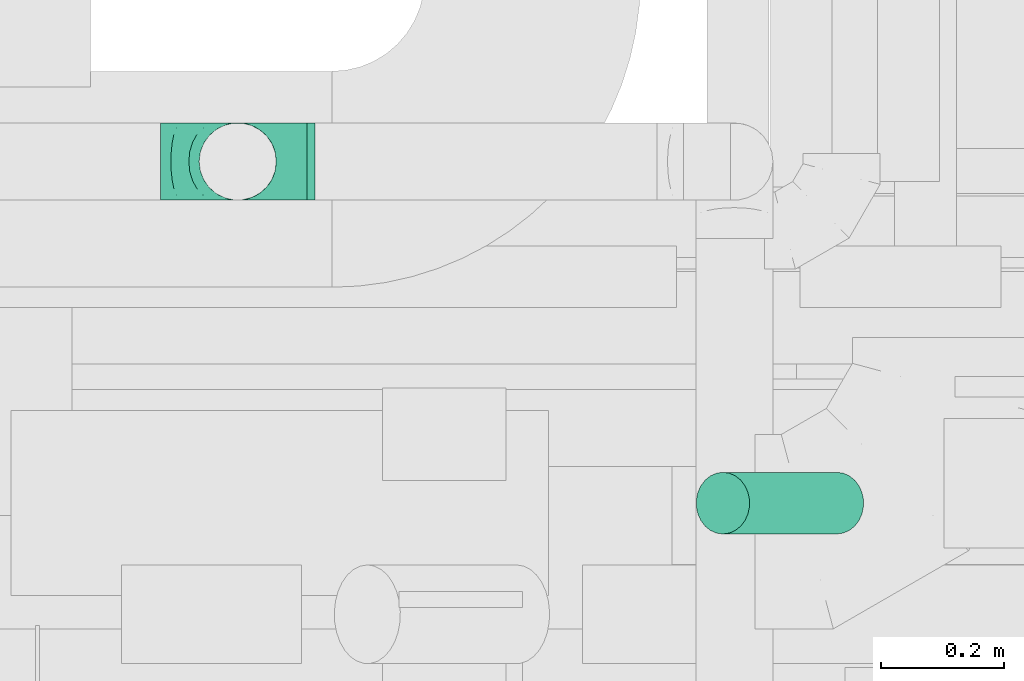
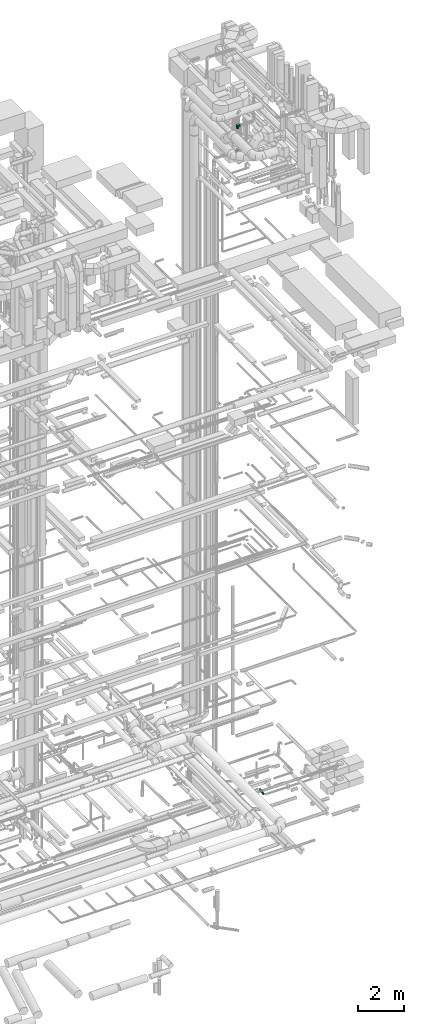
# One storey, part 262 of 337: 3 flow fittings, 1 flow segment.
"""IFC2X3 building model written with IfcOpenShell, lengths in millimetres."""

import ifcopenshell
import ifcopenshell.guid

model = None  # the IFC model being written
_history = None  # IfcOwnerHistory: only IFC2X3 demands one
_inside = {}  # id of a spatial element -> (the spatial element, [elements in it])
_under = {}  # id of a project, library or spatial element -> (it, [spatial elements below it])
_declared = {}  # id of a project -> (the project, [libraries it declares])
_typed = {}  # id of a type object -> (the type object, [elements of that type])
_made_of = {}  # id of a material, layer set ... -> (it, [elements and type objects made of it])


def new_model(schema):
    """Start an empty IFC model of exactly this schema.

    Asked for "IFC4X3", IfcOpenShell would pick the latest addendum, in which some entities
    have other attributes; the version numbers below select the first issue.
    IFC2X3 requires an IfcOwnerHistory on every rooted entity: one is made here for all.
    """
    global model, _history
    if schema == "IFC4X3":
        model = ifcopenshell.file(schema_version=(4, 3, 0, 0))
    else:
        model = ifcopenshell.file(schema=schema)
    _inside.clear()
    _under.clear()
    _declared.clear()
    _typed.clear()
    _made_of.clear()
    _history = None
    if model.schema == "IFC2X3":
        org = make("IfcOrganization", Name="unknown")
        user = make(
            "IfcPersonAndOrganization",
            ThePerson=make("IfcPerson", FamilyName="unknown"),
            TheOrganization=org,
        )
        app = make(
            "IfcApplication",
            ApplicationDeveloper=org,
            Version="unknown",
            ApplicationFullName="unknown",
            ApplicationIdentifier="unknown",
        )
        _history = make(
            "IfcOwnerHistory",
            OwningUser=user,
            OwningApplication=app,
            ChangeAction="ADDED",
            CreationDate=0,
        )
    return model


def make(cls, **values):
    """One entity of the class cls with the attributes given. An attribute that is None is left unset."""
    return model.create_entity(
        cls, **{name: value for name, value in values.items() if value is not None}
    )


def entity(cls, *values):
    """Any entity or typed value of the class cls, its attributes in the order of the schema. None: left unset."""
    e = model.create_entity(cls)
    for i, value in enumerate(values):
        if value is not None:
            e[i] = value
    return e


def rooted(cls, **values):
    """An entity with a GlobalId (a new one), such as an element, a storey or a relation."""
    return make(cls, GlobalId=ifcopenshell.guid.new(), OwnerHistory=_history, **values)


def si_unit(unit_type, name, prefix=None):
    """IfcSIUnit, for example si_unit("LENGTHUNIT", "METRE", prefix="MILLI")."""
    return make("IfcSIUnit", UnitType=unit_type, Prefix=prefix, Name=name)


def converted_unit(unit_type, name, factor, base, dimensions=None, offset=None):
    """IfcConversionBasedUnit, such as the inch: factor (a typed value) times the base unit."""
    return make(
        "IfcConversionBasedUnit"
        if offset is None
        else "IfcConversionBasedUnitWithOffset",
        ConversionOffset=offset,
        Dimensions=None
        if dimensions is None
        else entity("IfcDimensionalExponents", *dimensions),
        UnitType=unit_type,
        Name=name,
        ConversionFactor=make(
            "IfcMeasureWithUnit", ValueComponent=factor, UnitComponent=base
        ),
    )


def derived_unit(unit_type, elements):
    """IfcDerivedUnit: a product of units, each with its exponent."""
    return make(
        "IfcDerivedUnit",
        Elements=[
            make("IfcDerivedUnitElement", Unit=unit, Exponent=power)
            for unit, power in elements
        ],
        UnitType=unit_type,
    )


def assignment(units):
    """IfcUnitAssignment: the units of a project."""
    return None if units is None else make("IfcUnitAssignment", Units=units)


def point(xyz):
    """IfcCartesianPoint."""
    return None if xyz is None else make("IfcCartesianPoint", Coordinates=xyz)


def direction(xyz):
    """IfcDirection."""
    return None if xyz is None else make("IfcDirection", DirectionRatios=xyz)


def frame(location, z_axis=None, x_axis=None):
    """IfcAxis2Placement3D, a coordinate frame: its origin and axes. An axis left out is left unset."""
    return make(
        "IfcAxis2Placement3D",
        Location=point(location),
        Axis=direction(z_axis),
        RefDirection=direction(x_axis),
    )


def frame_2d(location, x_axis=None):
    """IfcAxis2Placement2D, a coordinate frame in the plane: its origin and x axis."""
    return make(
        "IfcAxis2Placement2D", Location=point(location), RefDirection=direction(x_axis)
    )


def origin():
    """The frame at (0, 0, 0) with its axes left unset."""
    return frame((0.0, 0.0, 0.0))


def origin_2d_with_axis():
    """The frame at (0, 0) in the plane with the x axis (1, 0) written out."""
    return frame_2d((0.0, 0.0), x_axis=(1.0, 0.0))


def place(relative_to, where):
    """IfcLocalPlacement: puts the frame where relative to a parent placement (None: the world)."""
    return make(
        "IfcLocalPlacement", PlacementRelTo=relative_to, RelativePlacement=where
    )


def context(
    kind, dimensions, precision=None, world=None, true_north=None, identifier=None
):
    """IfcGeometricRepresentationContext, for example the 3D "Model" context."""
    return make(
        "IfcGeometricRepresentationContext",
        ContextIdentifier=identifier,
        ContextType=kind,
        CoordinateSpaceDimension=dimensions,
        Precision=precision,
        WorldCoordinateSystem=world,
        TrueNorth=true_north,
    )


def subcontext(parent, identifier, kind, view, scale=None):
    """IfcGeometricRepresentationSubContext, for example "Body" below "Model"."""
    return make(
        "IfcGeometricRepresentationSubContext",
        ContextIdentifier=identifier,
        ContextType=kind,
        ParentContext=parent,
        TargetScale=scale,
        TargetView=view,
    )


def project(units=None, contexts=None):
    """IfcProject with its units and contexts."""
    return rooted(
        "IfcProject",
        Name="project",
        RepresentationContexts=contexts,
        UnitsInContext=assignment(units),
    )


def spatial(cls, under=None, at=None, **own):
    """A site, building, storey or space (cls), placed at a placement, below another one or the project."""
    s = rooted(cls, ObjectPlacement=at, **own)
    if under is not None:
        _under.setdefault(under.id(), (under, []))[1].append(s)
    return s


def profile(cls, at=None, kind="AREA", **sizes):
    """A parametric profile (cls). Its sizes go by their IFC names, for example OverallWidth=200.0."""
    return make(cls, ProfileType=kind, Position=at, **sizes)


def circle(**sizes):
    """IfcCircleProfileDef."""
    return profile("IfcCircleProfileDef", **sizes)


def extrude(swept, where, along, depth):
    """IfcExtrudedAreaSolid: the profile swept, set in the frame where, extruded along a direction by depth."""
    return make(
        "IfcExtrudedAreaSolid",
        SweptArea=swept,
        Position=where,
        ExtrudedDirection=direction(along),
        Depth=depth,
    )


def faces_of(points, faces, orient=None, outer=None):
    """IfcFace entities. A face is a list of loops; a loop is a list of indices into points, from 0.

    orient and outer hold one flag for each loop. By default every Orientation is true, the
    first loop of a face is its IfcFaceOuterBound and the others are IfcFaceBound.
    """
    made = []
    for i, loops in enumerate(faces):
        bounds = []
        for j, loop in enumerate(loops):
            is_outer = j == 0 if outer is None else outer[i][j]
            bounds.append(
                make(
                    "IfcFaceOuterBound" if is_outer else "IfcFaceBound",
                    Bound=make("IfcPolyLoop", Polygon=[points[k] for k in loop]),
                    Orientation=True if orient is None else orient[i][j],
                )
            )
        made.append(make("IfcFace", Bounds=bounds))
    return made


def faceted_brep(points, faces, orient=None, outer=None, voids=None):
    """IfcFacetedBrep: a solid bounded by flat faces; with voids (closed shells), ...WithVoids."""
    shared = [point(p) for p in points]
    hull = make("IfcClosedShell", CfsFaces=faces_of(shared, faces, orient, outer))
    if voids is None:
        return make("IfcFacetedBrep", Outer=hull)
    return make(
        "IfcFacetedBrepWithVoids",
        Outer=hull,
        Voids=[
            make(cls, CfsFaces=faces_of(shared, fs, o, b)) for cls, fs, o, b in voids
        ],
    )


def shape(context_of_items, identifier, shape_type, items):
    """IfcShapeRepresentation: the items that make up one representation, for example the "Body"."""
    return make(
        "IfcShapeRepresentation",
        ContextOfItems=context_of_items,
        RepresentationIdentifier=identifier,
        RepresentationType=shape_type,
        Items=items,
    )


def source(mapping_origin, context_of_items, identifier, shape_type, items):
    """IfcRepresentationMap: a shape defined once, which mapped items show again and again."""
    return make(
        "IfcRepresentationMap",
        MappingOrigin=mapping_origin,
        MappedRepresentation=shape(context_of_items, identifier, shape_type, items),
    )


def transform(
    local_origin,
    x_axis=None,
    y_axis=None,
    z_axis=None,
    scale=None,
    scale2=None,
    scale3=None,
    uniform=True,
):
    """IfcCartesianTransformationOperator3D, or its non-uniform kind. x_axis, y_axis, z_axis: its Axis1, 2, 3."""
    if uniform:
        return make(
            "IfcCartesianTransformationOperator3D",
            Axis1=direction(x_axis),
            Axis2=direction(y_axis),
            LocalOrigin=point(local_origin),
            Scale=scale,
            Axis3=direction(z_axis),
        )
    return make(
        "IfcCartesianTransformationOperator3DnonUniform",
        Axis1=direction(x_axis),
        Axis2=direction(y_axis),
        LocalOrigin=point(local_origin),
        Scale=scale,
        Axis3=direction(z_axis),
        Scale2=scale2,
        Scale3=scale3,
    )


def mapped(mapping_source, mapping_target):
    """IfcMappedItem: shows the shape of a source again, moved by a transform."""
    return make(
        "IfcMappedItem", MappingSource=mapping_source, MappingTarget=mapping_target
    )


def material(Name=None, Category=None):
    """IfcMaterial."""
    return make("IfcMaterial", Name=Name, Category=Category)


def made_of(thing, what):
    """Note that an element or type object is made of a material, layer set ...; save() writes the relation."""
    if what is not None:
        _made_of.setdefault(what.id(), (what, []))[1].append(thing)
    return thing


def type_object(cls, material=None, **own):
    """A type object (cls), such as IfcWallType, which elements share."""
    return made_of(rooted(cls, **own), material)


def type_shapes(of_type, sources):
    """Give a type object the sources (RepresentationMaps) that its elements show as mapped items."""
    of_type.RepresentationMaps = sources


def element(
    cls,
    number,
    at=None,
    inside=None,
    cuts=None,
    type_object=None,
    material=None,
    context=None,
    identifier="Body",
    shape_type=None,
    held_by="IfcProductDefinitionShape",
    body=None,
    shapes=None,
    **own,
):
    """One element of the class cls, such as IfcWall. Its Tag is "e" and its number.

    at: its placement. inside: the storey or other place that contains it. cuts: it is an
    opening in that element (IfcRelVoidsElement). A single representation is given by context,
    identifier, shape_type and body (its items); several are given by shapes. held_by: the class
    of the entity that holds the representations. save() writes the other relations.
    """
    e = rooted(cls, Tag="e%d" % number, ObjectPlacement=at, **own)
    if body is not None:
        shapes = [shape(context, identifier, shape_type, body)]
    if shapes is not None:
        e.Representation = make(held_by, Representations=shapes)
    if inside is not None:
        _inside.setdefault(inside.id(), (inside, []))[1].append(e)
    if cuts is not None:
        rooted(
            "IfcRelVoidsElement", RelatingBuildingElement=cuts, RelatedOpeningElement=e
        )
    if type_object is not None:
        _typed.setdefault(type_object.id(), (type_object, []))[1].append(e)
    return made_of(e, material)


def aggregate(whole, parts):
    """IfcRelAggregates: a whole, such as a stair, and the parts it consists of."""
    return rooted("IfcRelAggregates", RelatingObject=whole, RelatedObjects=parts)


def save(model, path):
    """Write the relations noted so far, then the file.

    IfcRelAggregates (storeys below a building ...), IfcRelContainedInSpatialStructure (elements
    in a storey), IfcRelDefinesByType, IfcRelAssociatesMaterial and IfcRelDeclares: one each for
    every whole, place, type object, material and project.
    """
    for whole, parts in _under.values():
        aggregate(whole, parts)
    for where, things in _inside.values():
        rooted(
            "IfcRelContainedInSpatialStructure",
            RelatedElements=things,
            RelatingStructure=where,
        )
    for kind, things in _typed.values():
        rooted("IfcRelDefinesByType", RelatedObjects=things, RelatingType=kind)
    for what, things in _made_of.values():
        rooted("IfcRelAssociatesMaterial", RelatedObjects=things, RelatingMaterial=what)
    for by, libraries in _declared.values():
        rooted("IfcRelDeclares", RelatingContext=by, RelatedDefinitions=libraries)
    model.write(path)


model = new_model("IFC2X3")

# Units and contexts
model_context = context("Model", 3, precision=0.01, world=origin(), true_north=direction((6.12303176911189e-17, 1.0)))
body_context = subcontext(model_context, "Body", "Model", "MODEL_VIEW")
ifc_project = project(units=[si_unit("LENGTHUNIT", "METRE", prefix="MILLI"), si_unit("AREAUNIT", "SQUARE_METRE"), si_unit("VOLUMEUNIT", "CUBIC_METRE"), converted_unit("PLANEANGLEUNIT", "DEGREE", entity("IfcRatioMeasure", 0.0174532925199433), si_unit("PLANEANGLEUNIT", "RADIAN"), dimensions=[0, 0, 0, 0, 0, 0, 0]), si_unit("MASSUNIT", "GRAM", prefix="KILO"), derived_unit("MASSDENSITYUNIT", [(si_unit("MASSUNIT", "GRAM", prefix="KILO"), 1), (si_unit("LENGTHUNIT", "METRE"), -3)]), derived_unit("MOMENTOFINERTIAUNIT", [(si_unit("LENGTHUNIT", "METRE"), 4)]), si_unit("TIMEUNIT", "SECOND"), si_unit("FREQUENCYUNIT", "HERTZ"), si_unit("THERMODYNAMICTEMPERATUREUNIT", "DEGREE_CELSIUS"), derived_unit("THERMALTRANSMITTANCEUNIT", [(si_unit("MASSUNIT", "GRAM", prefix="KILO"), 1), (si_unit("THERMODYNAMICTEMPERATUREUNIT", "KELVIN"), -1), (si_unit("TIMEUNIT", "SECOND"), -3)]), derived_unit("VOLUMETRICFLOWRATEUNIT", [(si_unit("LENGTHUNIT", "METRE"), 3), (si_unit("TIMEUNIT", "SECOND"), -1)]), derived_unit("MASSFLOWRATEUNIT", [(si_unit("MASSUNIT", "GRAM", prefix="KILO"), 1), (si_unit("TIMEUNIT", "SECOND"), -1)]), derived_unit("ROTATIONALFREQUENCYUNIT", [(si_unit("TIMEUNIT", "SECOND"), -1)]), si_unit("ELECTRICCURRENTUNIT", "AMPERE"), si_unit("ELECTRICVOLTAGEUNIT", "VOLT"), si_unit("POWERUNIT", "WATT"), si_unit("FORCEUNIT", "NEWTON", prefix="KILO"), si_unit("ILLUMINANCEUNIT", "LUX"), si_unit("LUMINOUSFLUXUNIT", "LUMEN"), si_unit("LUMINOUSINTENSITYUNIT", "CANDELA"), derived_unit("USERDEFINED", [(si_unit("MASSUNIT", "GRAM", prefix="KILO"), -1), (si_unit("LENGTHUNIT", "METRE"), -2), (si_unit("TIMEUNIT", "SECOND"), 3), (si_unit("LUMINOUSFLUXUNIT", "LUMEN"), 1)]), derived_unit("LINEARVELOCITYUNIT", [(si_unit("LENGTHUNIT", "METRE"), 1), (si_unit("TIMEUNIT", "SECOND"), -1)]), si_unit("PRESSUREUNIT", "PASCAL"), derived_unit("USERDEFINED", [(si_unit("LENGTHUNIT", "METRE"), -2), (si_unit("MASSUNIT", "GRAM", prefix="KILO"), 1), (si_unit("TIMEUNIT", "SECOND"), -2)]), derived_unit("LINEARFORCEUNIT", [(si_unit("MASSUNIT", "GRAM", prefix="KILO"), 1), (si_unit("LENGTHUNIT", "METRE"), 1), (si_unit("TIMEUNIT", "SECOND"), -2), (si_unit("LENGTHUNIT", "METRE"), -1)]), derived_unit("PLANARFORCEUNIT", [(si_unit("MASSUNIT", "GRAM", prefix="KILO"), 1), (si_unit("LENGTHUNIT", "METRE"), 1), (si_unit("TIMEUNIT", "SECOND"), -2), (si_unit("LENGTHUNIT", "METRE"), -2)])], contexts=[model_context])

# Site, building, storey
site_placement = place(None, origin())
site = spatial("IfcSite", under=ifc_project, at=site_placement, CompositionType="ELEMENT")
building_placement = place(site_placement, origin())
building = spatial("IfcBuilding", under=site, at=building_placement, CompositionType="ELEMENT")
storey_placement = place(building_placement, origin())
storey = spatial("IfcBuildingStorey", under=building, at=storey_placement, CompositionType="ELEMENT", Elevation=0.0)

# Flow segment
duct_segment_type = type_object("IfcDuctSegmentType", PredefinedType="NOTDEFINED")
flow_segment_placement = place(storey_placement, frame((69694.03, 9821.97, -976.6)))
element("IfcFlowSegment", 1, at=flow_segment_placement, inside=storey, type_object=duct_segment_type, context=body_context, shape_type="SweptSolid", body=[
    extrude(circle(Radius=50.0, at=origin_2d_with_axis()), frame((229.65, 51.6, 26.6), z_axis=(-0.499999999999976, 0.0, 0.866025403784453), x_axis=(0.0, -1.0, 0.0)), (0.0, 0.0, 1.0), 369.504214189099),
])

# Flow fittings
ifc_material = material()
duct_fitting_type_1 = type_object("IfcDuctFittingType", PredefinedType="NOTDEFINED", material=ifc_material)
shared_shape_1 = source(origin(), body_context, "Body", "Brep", [
    faceted_brep([(-125.0, 0.0, -62.5), (-125.0, -16.18, -60.37), (-125.0, -31.25, -54.13), (-125.0, -44.19, -44.19), (-125.0, -54.13, -31.25), (-125.0, -60.37, -16.18), (-125.0, -62.5, 0.0), (-125.0, -60.37, 16.18), (-125.0, -54.13, 31.25), (-125.0, -44.19, 44.19), (-125.0, -31.25, 54.13), (-125.0, -16.18, 60.37), (-125.0, 0.0, 62.5), (-125.0, 16.18, 60.37), (-125.0, 31.25, 54.13), (-125.0, 44.19, 44.19), (-125.0, 54.13, 31.25), (-125.0, 60.37, 16.18), (-125.0, 62.5, 0.0), (-125.0, 60.37, -16.18), (-125.0, 54.13, -31.25), (-125.0, 44.19, -44.19), (-125.0, 31.25, -54.13), (-125.0, 16.18, -60.37), (-95.84, 16.18, 60.37), (-99.88, 31.25, 54.13), (-91.51, 0.0, 62.5), (-103.35, 44.19, 44.19), (-107.68, 60.37, 16.18), (-108.25, 62.5, 0.0), (-106.01, 54.13, 31.25), (-106.01, 54.13, -31.25), (-103.35, 44.19, -44.19), (-107.68, 60.37, -16.18), (-95.84, 16.18, -60.37), (-91.51, 0.0, -62.5), (-99.88, 31.25, -54.13), (-87.17, -16.18, -60.37), (-83.13, -31.25, -54.13), (-79.66, -44.19, -44.19), (-77.0, -54.13, -31.25), (-75.33, -60.37, -16.18), (-74.76, -62.5, 0.0), (-75.33, -60.37, 16.18), (-77.0, -54.13, 31.25), (-79.66, -44.19, 44.19), (-83.13, -31.25, 54.13), (-87.17, -16.18, 60.37), (-45.34, 45.34, 60.37), (-56.37, 56.37, 54.13), (-33.49, 33.49, 62.5), (-65.85, 65.85, 44.19), (-73.12, 73.12, 31.25), (-77.69, 77.69, 16.18), (-79.25, 79.25, 0.0), (-77.69, 77.69, -16.18), (-73.12, 73.12, -31.25), (-65.85, 65.85, -44.19), (-45.34, 45.34, -60.37), (-33.49, 33.49, -62.5), (-56.37, 56.37, -54.13), (-21.65, 21.65, -60.37), (-10.62, 10.62, -54.13), (-1.14, 1.14, -44.19), (6.13, -6.13, -31.25), (10.7, -10.7, -16.18), (12.26, -12.26, 0.0), (10.7, -10.7, 16.18), (6.13, -6.13, 31.25), (-1.14, 1.14, 44.19), (-10.62, 10.62, 54.13), (-21.65, 21.65, 60.37), (-16.18, 95.84, 60.37), (-31.25, 99.88, 54.13), (0.0, 91.51, 62.5), (-44.19, 103.35, 44.19), (-54.13, 106.01, 31.25), (-60.37, 107.68, 16.18), (-62.5, 108.25, 0.0), (-60.37, 107.68, -16.18), (-54.13, 106.01, -31.25), (-44.19, 103.35, -44.19), (-16.18, 95.84, -60.37), (0.0, 91.51, -62.5), (-31.25, 99.88, -54.13), (16.18, 87.17, -60.37), (31.25, 83.13, -54.13), (44.19, 79.66, -44.19), (54.13, 77.0, -31.25), (60.37, 75.33, -16.18), (62.5, 74.76, 0.0), (60.37, 75.33, 16.18), (54.13, 77.0, 31.25), (44.19, 79.66, 44.19), (31.25, 83.13, 54.13), (16.18, 87.17, 60.37), (-16.18, 125.0, -60.37), (-31.25, 125.0, -54.13), (-44.19, 125.0, -44.19), (-54.13, 125.0, -31.25), (-60.37, 125.0, -16.18), (-62.5, 125.0, 0.0), (-60.37, 125.0, 16.18), (-54.13, 125.0, 31.25), (-44.19, 125.0, 44.19), (-31.25, 125.0, 54.13), (-16.18, 125.0, 60.37), (0.0, 125.0, 62.5), (16.18, 125.0, 60.37), (31.25, 125.0, 54.13), (44.19, 125.0, 44.19), (54.13, 125.0, 31.25), (60.37, 125.0, 16.18), (62.5, 125.0, 0.0), (60.37, 125.0, -16.18), (54.13, 125.0, -31.25), (44.19, 125.0, -44.19), (31.25, 125.0, -54.13), (16.18, 125.0, -60.37), (0.0, 125.0, -62.5)], [[[0, 1, 2, 3, 4, 5, 6, 7, 8, 9, 10, 11, 12, 13, 14, 15, 16, 17, 18, 19, 20, 21, 22, 23]], [[24, 25, 14, 13]], [[26, 24, 13, 12]], [[14, 25, 27, 15]], [[28, 29, 18, 17]], [[30, 28, 17, 16]], [[15, 27, 30, 16]], [[20, 31, 32, 21]], [[33, 31, 20, 19]], [[18, 29, 33, 19]], [[34, 35, 0, 23]], [[36, 34, 23, 22]], [[21, 32, 36, 22]], [[1, 0, 35, 37]], [[2, 1, 37, 38]], [[38, 39, 3, 2]], [[5, 4, 40, 41]], [[6, 5, 41, 42]], [[39, 40, 4, 3]], [[6, 42, 43, 7]], [[7, 43, 44, 8]], [[45, 9, 8, 44]], [[9, 45, 46, 10]], [[10, 46, 47, 11]], [[26, 12, 11, 47]], [[48, 49, 25, 24]], [[50, 48, 24, 26]], [[27, 25, 49, 51]], [[52, 53, 28, 30]], [[51, 52, 30, 27]], [[29, 28, 53, 54]], [[55, 56, 31, 33]], [[54, 55, 33, 29]], [[57, 32, 31, 56]], [[58, 59, 35, 34]], [[60, 58, 34, 36]], [[57, 60, 36, 32]], [[37, 35, 59, 61]], [[38, 37, 61, 62]], [[39, 38, 62, 63]], [[41, 40, 64, 65]], [[42, 41, 65, 66]], [[63, 64, 40, 39]], [[43, 42, 66, 67]], [[44, 43, 67, 68]], [[68, 69, 45, 44]], [[46, 45, 69, 70]], [[47, 46, 70, 71]], [[26, 47, 71, 50]], [[72, 73, 49, 48]], [[74, 72, 48, 50]], [[51, 49, 73, 75]], [[76, 77, 53, 52]], [[75, 76, 52, 51]], [[54, 53, 77, 78]], [[79, 80, 56, 55]], [[78, 79, 55, 54]], [[81, 57, 56, 80]], [[82, 83, 59, 58]], [[84, 82, 58, 60]], [[81, 84, 60, 57]], [[61, 59, 83, 85]], [[62, 61, 85, 86]], [[63, 62, 86, 87]], [[65, 64, 88, 89]], [[66, 65, 89, 90]], [[87, 88, 64, 63]], [[67, 66, 90, 91]], [[68, 67, 91, 92]], [[92, 93, 69, 68]], [[70, 69, 93, 94]], [[71, 70, 94, 95]], [[50, 71, 95, 74]], [[96, 97, 98, 99, 100, 101, 102, 103, 104, 105, 106, 107, 108, 109, 110, 111, 112, 113, 114, 115, 116, 117, 118, 119]], [[72, 74, 107, 106]], [[73, 72, 106, 105]], [[75, 73, 105, 104]], [[77, 76, 103, 102]], [[78, 77, 102, 101]], [[75, 104, 103, 76]], [[78, 101, 100, 79]], [[79, 100, 99, 80]], [[80, 99, 98, 81]], [[96, 119, 83, 82]], [[97, 96, 82, 84]], [[84, 81, 98, 97]], [[83, 119, 118, 85]], [[85, 118, 117, 86]], [[116, 87, 86, 117]], [[88, 115, 114, 89]], [[89, 114, 113, 90]], [[115, 88, 87, 116]], [[91, 90, 113, 112]], [[92, 91, 112, 111]], [[111, 110, 93, 92]], [[95, 94, 109, 108]], [[74, 95, 108, 107]], [[110, 109, 94, 93]]]),
])
type_shapes(duct_fitting_type_1, [shared_shape_1])
for number, where, z_axis, x_axis in (
    (2, (68952.45, 10427.27, 33015.0), (0.0, 1.0, 0.0), (0.0, 0.0, -1.0)),
    (3, (68952.45, 10427.27, 35100.0), (0.0, 1.0, 0.0), (0.0, 0.0, 1.0)),
):
    element("IfcFlowFitting", number, at=place(storey_placement, frame(where, z_axis=z_axis, x_axis=x_axis)), inside=storey, type_object=duct_fitting_type_1, material=ifc_material, context=body_context, shape_type="MappedRepresentation", body=[
        mapped(shared_shape_1, transform((0.0, 0.0, 0.0), scale=1.0)),
    ])
duct_fitting_type_2 = type_object("IfcDuctFittingType", PredefinedType="NOTDEFINED", material=ifc_material)
shared_shape_2 = source(origin(), body_context, "Body", "Brep", [
    faceted_brep([(9.35, -9.35, -61.8), (112.5, 0.0, -62.5), (112.5, -16.18, -60.37), (112.5, -31.25, -54.13), (27.61, -27.61, -56.07), (36.24, -36.24, -50.92), (112.5, -44.19, -44.19), (0.0, 0.0, -62.5), (-9.35, -9.35, -61.8), (-112.5, 0.0, -62.5), (18.59, -18.59, -59.67), (51.42, -51.42, -35.53), (112.5, -54.13, -31.25), (57.22, -57.22, -25.14), (112.5, -60.37, -16.18), (61.11, -61.11, -13.09), (112.5, -62.5, 0.0), (44.28, -44.28, -44.11), (62.5, -62.5, 0.0), (-112.5, -62.5, 0.0), (-61.11, -61.11, -13.09), (-62.5, -62.5, 0.0), (61.11, -61.11, 13.09), (-61.11, -61.11, 13.09), (112.5, -60.37, 16.18), (57.22, -57.22, 25.14), (112.5, -54.13, 31.25), (112.5, -44.19, 44.19), (44.28, -44.28, 44.11), (51.42, -51.42, 35.53), (36.24, -36.24, 50.92), (112.5, -31.25, 54.13), (27.61, -27.61, 56.07), (112.5, -16.18, 60.37), (9.35, -9.35, 61.8), (112.5, 0.0, 62.5), (18.59, -18.59, 59.67), (0.0, 0.0, 62.5), (-9.35, -9.35, 61.8), (-112.5, 0.0, 62.5), (16.18, -112.5, -60.37), (31.25, -112.5, -54.13), (44.19, -112.5, -44.19), (54.13, -112.5, -31.25), (60.37, -112.5, -16.18), (62.5, -112.5, 0.0), (60.37, -112.5, 16.18), (54.13, -112.5, 31.25), (44.19, -112.5, 44.19), (31.25, -112.5, 54.13), (16.18, -112.5, 60.37), (0.0, -112.5, 62.5), (-16.18, -112.5, 60.37), (-31.25, -112.5, 54.13), (-44.19, -112.5, 44.19), (-54.13, -112.5, 31.25), (-60.37, -112.5, 16.18), (-62.5, -112.5, 0.0), (-60.37, -112.5, -16.18), (-54.13, -112.5, -31.25), (-44.19, -112.5, -44.19), (-31.25, -112.5, -54.13), (-16.18, -112.5, -60.37), (0.0, -112.5, -62.5), (-27.61, -27.61, -56.07), (-36.24, -36.24, -50.92), (-18.59, -18.59, -59.67), (-51.42, -51.42, -35.53), (-57.22, -57.22, -25.14), (-44.28, -44.28, -44.11), (-57.22, -57.22, 25.14), (-44.28, -44.28, 44.11), (-51.42, -51.42, 35.53), (-36.24, -36.24, 50.92), (-27.61, -27.61, 56.07), (-18.59, -18.59, 59.67), (-112.5, -16.18, -60.37), (-112.5, -31.25, -54.13), (-112.5, -44.19, -44.19), (-112.5, -54.13, -31.25), (-112.5, -60.37, -16.18), (-112.5, -60.37, 16.18), (-112.5, -54.13, 31.25), (-112.5, -44.19, 44.19), (-112.5, -31.25, 54.13), (-112.5, -16.18, 60.37), (-112.5, 16.18, 60.37), (-112.5, 31.25, 54.13), (-112.5, 44.19, 44.19), (-112.5, 54.13, 31.25), (-112.5, 60.37, 16.18), (-112.5, 62.5, 0.0), (-112.5, 60.37, -16.18), (-112.5, 54.13, -31.25), (-112.5, 44.19, -44.19), (-112.5, 31.25, -54.13), (-112.5, 16.18, -60.37), (112.5, 16.18, -60.37), (112.5, 31.25, -54.13), (112.5, 44.19, -44.19), (112.5, 54.13, -31.25), (112.5, 60.37, -16.18), (112.5, 62.5, 0.0), (112.5, 60.37, 16.18), (112.5, 54.13, 31.25), (112.5, 44.19, 44.19), (112.5, 31.25, 54.13), (112.5, 16.18, 60.37)], [[[0, 1, 2]], [[2, 3, 4]], [[5, 3, 6]], [[5, 4, 3]], [[0, 7, 1]], [[7, 8, 9]], [[4, 10, 2]], [[0, 2, 10]], [[11, 6, 12]], [[13, 12, 14]], [[15, 14, 16]], [[11, 17, 6]], [[15, 13, 14]], [[18, 15, 16]], [[19, 20, 21]], [[11, 12, 13]], [[6, 17, 5]], [[22, 18, 16]], [[21, 23, 19]], [[22, 16, 24]], [[25, 24, 26]], [[25, 22, 24]], [[27, 28, 29]], [[25, 26, 29]], [[29, 26, 27]], [[30, 27, 31]], [[32, 31, 33]], [[34, 33, 35]], [[32, 30, 31]], [[34, 36, 33]], [[37, 34, 35]], [[38, 37, 39]], [[32, 33, 36]], [[27, 30, 28]], [[40, 41, 42, 43, 44, 45, 46, 47, 48, 49, 50, 51, 52, 53, 54, 55, 56, 57, 58, 59, 60, 61, 62, 63]], [[34, 51, 50]], [[50, 49, 32]], [[30, 49, 48]], [[30, 32, 49]], [[34, 37, 51]], [[32, 36, 50]], [[34, 50, 36]], [[29, 48, 47]], [[25, 47, 46]], [[22, 46, 45]], [[29, 28, 48]], [[22, 25, 46]], [[18, 22, 45]], [[29, 47, 25]], [[48, 28, 30]], [[15, 18, 45]], [[15, 45, 44]], [[13, 44, 43]], [[13, 15, 44]], [[42, 17, 11]], [[13, 43, 11]], [[11, 43, 42]], [[5, 42, 41]], [[4, 41, 40]], [[0, 40, 63]], [[4, 5, 41]], [[0, 10, 40]], [[7, 0, 63]], [[4, 40, 10]], [[42, 5, 17]], [[8, 63, 62]], [[62, 61, 64]], [[65, 61, 60]], [[65, 64, 61]], [[8, 7, 63]], [[64, 66, 62]], [[8, 62, 66]], [[67, 60, 59]], [[68, 59, 58]], [[20, 58, 57]], [[67, 69, 60]], [[20, 68, 58]], [[21, 20, 57]], [[67, 59, 68]], [[60, 69, 65]], [[23, 21, 57]], [[23, 57, 56]], [[70, 56, 55]], [[70, 23, 56]], [[54, 71, 72]], [[70, 55, 72]], [[72, 55, 54]], [[73, 54, 53]], [[74, 53, 52]], [[38, 52, 51]], [[74, 73, 53]], [[38, 75, 52]], [[37, 38, 51]], [[74, 52, 75]], [[54, 73, 71]], [[9, 76, 77, 78, 79, 80, 19, 81, 82, 83, 84, 85, 39, 86, 87, 88, 89, 90, 91, 92, 93, 94, 95, 96]], [[97, 98, 99, 100, 101, 102, 103, 104, 105, 106, 107, 35, 33, 31, 27, 26, 24, 16, 14, 12, 6, 3, 2, 1]], [[37, 35, 107, 86, 39]], [[87, 86, 107, 106]], [[106, 105, 88, 87]], [[89, 88, 105, 104]], [[90, 89, 104, 103]], [[91, 90, 103, 102]], [[101, 100, 93, 92]], [[102, 101, 92, 91]], [[100, 99, 94, 93]], [[95, 94, 99, 98]], [[96, 95, 98, 97]], [[7, 9, 96, 97, 1]], [[66, 64, 76]], [[8, 66, 76]], [[9, 8, 76]], [[77, 65, 78]], [[77, 76, 64]], [[65, 77, 64]], [[69, 67, 78]], [[68, 20, 80]], [[67, 68, 79]], [[78, 67, 79]], [[20, 19, 80]], [[80, 79, 68]], [[69, 78, 65]], [[23, 70, 81]], [[82, 72, 83]], [[70, 72, 82]], [[19, 23, 81]], [[70, 82, 81]], [[72, 71, 83]], [[74, 75, 85]], [[75, 38, 85]], [[83, 73, 84]], [[73, 83, 71]], [[74, 84, 73]], [[74, 85, 84]], [[38, 39, 85]]]),
])
type_shapes(duct_fitting_type_2, [shared_shape_2])
flow_fitting_placement = place(storey_placement, frame((68952.45, 10427.27, 34320.0), z_axis=(0.0, -1.0, 0.0), x_axis=(0.0, 0.0, 1.0)))
element("IfcFlowFitting", 4, at=flow_fitting_placement, inside=storey, type_object=duct_fitting_type_2, material=ifc_material, context=body_context, shape_type="MappedRepresentation", body=[
    mapped(shared_shape_2, transform((0.0, 0.0, 0.0), scale=1.0)),
])

save(model, "model.ifc")
